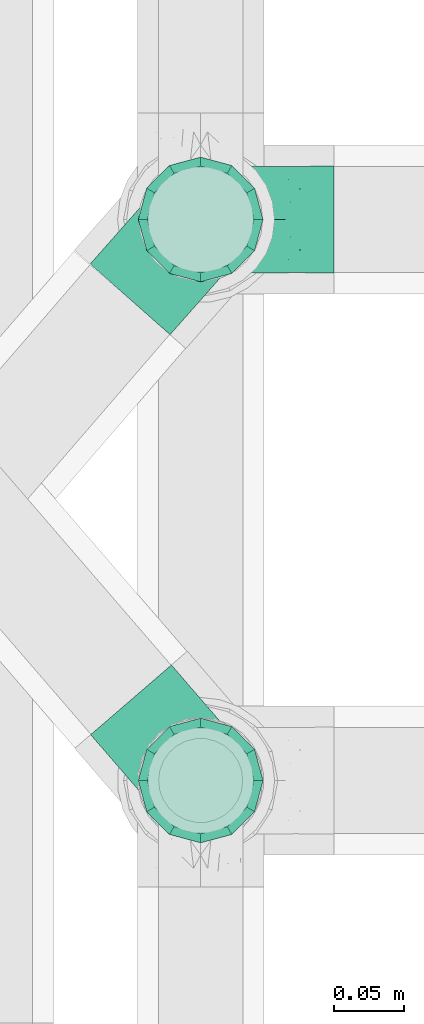
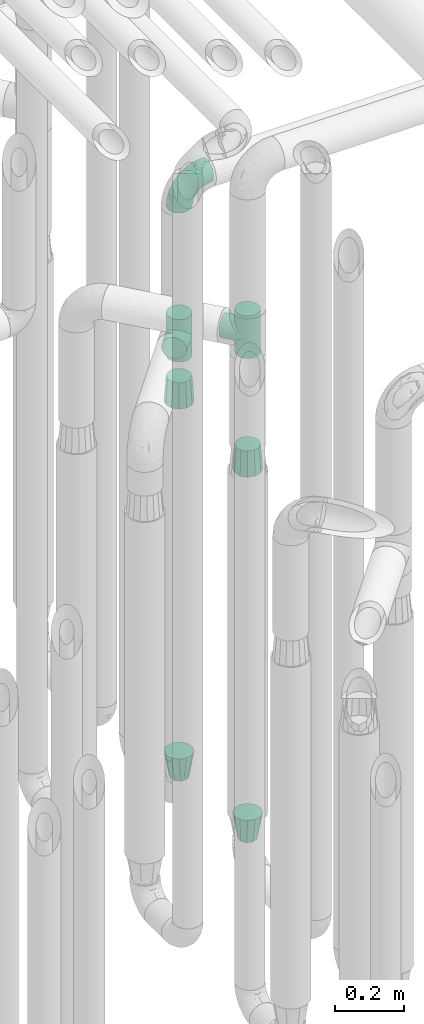
# One storey, part 618 of 827: 7 flow fittings.
"""IFC2X3 building model written with IfcOpenShell, lengths in millimetres."""

from ifc_helpers import new_model, entity, si_unit, converted_unit, derived_unit, direction, frame, origin, place, context, subcontext, project, spatial, faceted_brep, source, transform, mapped, material, type_object, type_shapes, element, save


model = new_model("IFC2X3")

# Units and contexts
model_context = context("Model", 3, precision=0.01, world=origin(), true_north=direction((6.12303176911189e-17, 1.0)))
body_context = subcontext(model_context, "Body", "Model", "MODEL_VIEW")
ifc_project = project(units=[si_unit("LENGTHUNIT", "METRE", prefix="MILLI"), si_unit("AREAUNIT", "SQUARE_METRE"), si_unit("VOLUMEUNIT", "CUBIC_METRE"), converted_unit("PLANEANGLEUNIT", "DEGREE", entity("IfcRatioMeasure", 0.0174532925199433), si_unit("PLANEANGLEUNIT", "RADIAN"), dimensions=[0, 0, 0, 0, 0, 0, 0]), si_unit("MASSUNIT", "GRAM", prefix="KILO"), derived_unit("MASSDENSITYUNIT", [(si_unit("MASSUNIT", "GRAM", prefix="KILO"), 1), (si_unit("LENGTHUNIT", "METRE"), -3)]), derived_unit("MOMENTOFINERTIAUNIT", [(si_unit("LENGTHUNIT", "METRE"), 4)]), si_unit("TIMEUNIT", "SECOND"), si_unit("FREQUENCYUNIT", "HERTZ"), si_unit("THERMODYNAMICTEMPERATUREUNIT", "DEGREE_CELSIUS"), derived_unit("THERMALTRANSMITTANCEUNIT", [(si_unit("MASSUNIT", "GRAM", prefix="KILO"), 1), (si_unit("THERMODYNAMICTEMPERATUREUNIT", "KELVIN"), -1), (si_unit("TIMEUNIT", "SECOND"), -3)]), derived_unit("VOLUMETRICFLOWRATEUNIT", [(si_unit("LENGTHUNIT", "METRE"), 3), (si_unit("TIMEUNIT", "SECOND"), -1)]), derived_unit("MASSFLOWRATEUNIT", [(si_unit("MASSUNIT", "GRAM", prefix="KILO"), 1), (si_unit("TIMEUNIT", "SECOND"), -1)]), derived_unit("ROTATIONALFREQUENCYUNIT", [(si_unit("TIMEUNIT", "SECOND"), -1)]), si_unit("ELECTRICCURRENTUNIT", "AMPERE"), si_unit("ELECTRICVOLTAGEUNIT", "VOLT"), si_unit("POWERUNIT", "WATT"), si_unit("FORCEUNIT", "NEWTON", prefix="KILO"), si_unit("ILLUMINANCEUNIT", "LUX"), si_unit("LUMINOUSFLUXUNIT", "LUMEN"), si_unit("LUMINOUSINTENSITYUNIT", "CANDELA"), derived_unit("USERDEFINED", [(si_unit("MASSUNIT", "GRAM", prefix="KILO"), -1), (si_unit("LENGTHUNIT", "METRE"), -2), (si_unit("TIMEUNIT", "SECOND"), 3), (si_unit("LUMINOUSFLUXUNIT", "LUMEN"), 1)]), derived_unit("LINEARVELOCITYUNIT", [(si_unit("LENGTHUNIT", "METRE"), 1), (si_unit("TIMEUNIT", "SECOND"), -1)]), si_unit("PRESSUREUNIT", "PASCAL"), derived_unit("USERDEFINED", [(si_unit("LENGTHUNIT", "METRE"), -2), (si_unit("MASSUNIT", "GRAM", prefix="KILO"), 1), (si_unit("TIMEUNIT", "SECOND"), -2)]), derived_unit("LINEARFORCEUNIT", [(si_unit("MASSUNIT", "GRAM", prefix="KILO"), 1), (si_unit("LENGTHUNIT", "METRE"), 1), (si_unit("TIMEUNIT", "SECOND"), -2), (si_unit("LENGTHUNIT", "METRE"), -1)]), derived_unit("PLANARFORCEUNIT", [(si_unit("MASSUNIT", "GRAM", prefix="KILO"), 1), (si_unit("LENGTHUNIT", "METRE"), 1), (si_unit("TIMEUNIT", "SECOND"), -2), (si_unit("LENGTHUNIT", "METRE"), -2)])], contexts=[model_context])

# Site, building, storey
site_placement = place(None, origin())
site = spatial("IfcSite", under=ifc_project, at=site_placement, CompositionType="ELEMENT")
building_placement = place(site_placement, origin())
building = spatial("IfcBuilding", under=site, at=building_placement, CompositionType="ELEMENT")
storey_placement = place(building_placement, frame((0.0, 0.0, 28200.0)))
storey = spatial("IfcBuildingStorey", under=building, at=storey_placement, Name="08", CompositionType="ELEMENT", Elevation=28200.0)

# Flow fittings
ifc_material = material()
pipe_fitting_type_1 = type_object("IfcPipeFittingType", Name="ADSK_1", PredefinedType="NOTDEFINED", material=ifc_material)
shared_shape_1 = source(origin(), body_context, "Body", "Brep", [
    faceted_brep([(-95.0, 19.02, -32.95), (-95.0, 9.85, -36.75), (-95.0, 0.0, -38.05), (-95.0, -9.85, -36.75), (-95.0, -19.03, -32.95), (-95.0, -26.91, -26.91), (-95.0, -32.95, -19.03), (-95.0, -36.75, -9.85), (-95.0, -38.05, 0.0), (-95.0, -36.75, 9.85), (-95.0, -32.95, 19.02), (-95.0, -26.91, 26.91), (-95.0, -19.03, 32.95), (-95.0, -9.85, 36.75), (-95.0, 0.0, 38.05), (-95.0, 9.85, 36.75), (-95.0, 19.02, 32.95), (-95.0, 26.91, 26.91), (-95.0, 32.95, 19.02), (-95.0, 36.75, 9.85), (-95.0, 38.05, 0.0), (-95.0, 36.75, -9.85), (-95.0, 32.95, -19.03), (-95.0, 26.91, -26.91), (0.0, 95.0, -38.05), (-9.85, 95.0, -36.75), (-19.02, 95.0, -32.95), (-26.91, 95.0, -26.91), (-32.95, 95.0, -19.03), (-36.75, 95.0, -9.85), (-38.05, 95.0, 0.0), (-36.75, 95.0, 9.85), (-32.95, 95.0, 19.02), (-26.91, 95.0, 26.91), (-19.02, 95.0, 32.95), (-9.85, 95.0, 36.75), (0.0, 95.0, 38.05), (9.85, 95.0, 36.75), (19.03, 95.0, 32.95), (26.91, 95.0, 26.91), (32.95, 95.0, 19.02), (36.75, 95.0, 9.85), (38.05, 95.0, 0.0), (36.75, 95.0, -9.85), (32.95, 95.0, -19.03), (26.91, 95.0, -26.91), (19.03, 95.0, -32.95), (9.85, 95.0, -36.75), (-7.99, -4.96, 6.3), (-0.92, 0.92, 0.0), (4.62, 8.1, 8.01), (-76.19, -35.57, 0.0), (-64.32, -32.32, 12.43), (20.51, 62.45, 28.68), (-60.56, -33.52, 0.0), (-70.4, -13.47, 34.42), (-39.61, -5.88, 32.32), (-49.6, 2.07, 37.1), (-70.34, -28.81, 21.71), (14.64, 40.81, 26.5), (5.88, 39.61, 32.32), (3.59, 20.77, 25.31), (-40.45, 68.06, 16.75), (-62.45, -20.51, 28.68), (-44.52, -26.87, 0.0), (-28.47, -20.22, 0.0), (-26.43, -17.83, 8.75), (-76.1, 39.63, 10.76), (-72.74, 37.58, 18.19), (-60.35, 46.18, 14.61), (-13.4, 13.4, 32.12), (-20.77, -3.59, 25.31), (-14.66, 81.47, 35.56), (-6.22, 71.26, 37.92), (-57.5, 42.48, 22.79), (-15.0, 34.74, 37.7), (-27.1, 12.08, 36.05), (-9.2, 28.81, 35.63), (-79.98, 23.7, 30.95), (-73.68, -4.3, 37.48), (-30.74, 21.67, 37.97), (-62.36, 47.59, 6.79), (-72.71, 32.83, 24.69), (-67.42, 7.02, 37.95), (-32.13, 75.27, 24.51), (-43.46, 51.47, 26.26), (-24.98, 73.15, 31.29), (20.59, 41.28, 19.85), (7.79, 16.09, 15.86), (-73.21, 42.39, 0.0), (-54.73, 54.73, 0.0), (-73.44, 15.79, 35.79), (-5.94, 4.32, 20.43), (28.81, 70.34, 21.71), (32.32, 64.32, 12.43), (-53.59, 26.2, 35.09), (-52.02, 19.31, 37.21), (21.38, 33.53, 10.34), (26.87, 44.52, 0.0), (-48.28, 12.14, 38.05), (4.3, 73.68, 37.48), (-44.08, -25.52, 12.79), (-41.28, -20.59, 19.85), (35.57, 76.19, 0.0), (-47.26, 54.3, 20.18), (-47.4, 61.99, 8.58), (-42.39, 73.21, 0.0), (-39.67, 78.86, 7.21), (-45.69, 36.84, 33.11), (-32.83, 50.13, 33.35), (13.47, 70.4, 34.42), (-18.25, 63.73, 36.07), (-40.63, -13.75, 27.22), (-16.63, 46.37, 37.95), (-53.47, 38.79, 28.59), (-26.07, 48.54, 36.15), (-34.51, 34.51, 36.86), (-2.07, 49.6, 37.1), (-22.79, -10.49, 19.23), (-61.73, 28.67, 31.87), (9.65, 14.7, 0.0), (20.22, 28.47, 0.0), (33.52, 60.56, 0.0), (-11.42, -5.44, 13.25), (-14.7, -9.65, 0.0), (-81.47, 14.66, -35.56), (-62.45, -20.51, -28.68), (-71.26, 6.22, -37.92), (-75.27, 32.13, -24.51), (-73.15, 24.98, -31.29), (13.47, 70.4, -34.42), (5.88, 39.61, -32.32), (-2.07, 49.6, -37.1), (-78.86, 39.67, -7.21), (-70.4, -13.47, -34.42), (-39.61, -5.88, -32.32), (-61.99, 47.4, -8.58), (32.32, 64.32, -12.43), (28.81, 70.34, -21.71), (-63.73, 18.25, -36.07), (-50.13, 32.83, -33.35), (4.3, 73.68, -37.48), (-7.02, 67.42, -37.95), (-39.63, 76.1, -10.76), (-46.18, 60.35, -14.61), (-47.59, 62.36, -6.79), (-64.32, -32.32, -12.43), (-26.2, 53.59, -35.09), (-15.79, 73.44, -35.79), (-19.31, 52.02, -37.21), (-37.58, 72.74, -18.19), (-70.34, -28.81, -21.71), (-42.48, 57.5, -22.79), (-38.79, 53.47, -28.59), (-51.47, 43.46, -26.26), (-32.83, 72.71, -24.69), (-46.37, 16.63, -37.95), (-73.68, -4.3, -37.48), (-41.28, -20.59, -19.85), (-44.08, -25.52, -12.79), (13.75, 40.63, -27.22), (20.51, 62.45, -28.68), (-68.06, 40.45, -16.75), (-54.3, 47.26, -20.18), (-12.14, 48.28, -38.05), (-21.67, 30.74, -37.97), (-36.84, 45.69, -33.11), (-11.42, -5.44, -13.25), (7.79, 16.09, -15.86), (4.62, 8.1, -8.01), (-23.7, 79.98, -30.95), (-26.43, -17.83, -8.75), (-7.99, -4.96, -6.3), (-40.81, -14.64, -26.5), (-20.77, -3.59, -25.31), (-34.74, 15.0, -37.7), (-12.08, 27.1, -36.05), (-28.81, 9.2, -35.63), (-22.79, -10.49, -19.23), (21.38, 33.53, -10.34), (20.59, 41.28, -19.85), (-48.54, 26.07, -36.15), (-49.6, 2.07, -37.1), (-13.4, 13.4, -32.12), (3.59, 20.77, -25.31), (-28.67, 61.73, -31.87), (-34.51, 34.51, -36.86), (-5.94, 4.32, -20.43)], [[[0, 1, 2, 3, 4, 5, 6, 7, 8, 9, 10, 11, 12, 13, 14, 15, 16, 17, 18, 19, 20, 21, 22, 23]], [[24, 25, 26, 27, 28, 29, 30, 31, 32, 33, 34, 35, 36, 37, 38, 39, 40, 41, 42, 43, 44, 45, 46, 47]], [[48, 49, 50]], [[51, 52, 9]], [[53, 39, 38]], [[9, 52, 10]], [[54, 52, 51]], [[55, 56, 57]], [[11, 10, 58]], [[59, 60, 61]], [[32, 31, 62]], [[63, 12, 11]], [[63, 55, 12]], [[64, 65, 66]], [[67, 68, 69]], [[70, 56, 71]], [[35, 72, 73]], [[69, 68, 74]], [[75, 76, 77]], [[16, 78, 17]], [[13, 79, 14]], [[76, 75, 80]], [[67, 69, 81]], [[18, 17, 82]], [[14, 79, 83]], [[20, 19, 67]], [[84, 85, 86]], [[87, 61, 88]], [[89, 81, 90]], [[18, 82, 68]], [[15, 91, 16]], [[14, 83, 15]], [[71, 92, 61]], [[17, 78, 82]], [[93, 87, 94]], [[95, 91, 96]], [[97, 98, 94]], [[86, 72, 34]], [[96, 99, 80]], [[37, 36, 100]], [[40, 39, 93]], [[40, 94, 41]], [[64, 66, 101]], [[93, 94, 40]], [[58, 102, 63]], [[94, 103, 41]], [[94, 87, 97]], [[104, 69, 74]], [[34, 33, 86]], [[105, 69, 104]], [[52, 58, 10]], [[106, 107, 30]], [[108, 109, 85]], [[105, 106, 90]], [[53, 110, 60]], [[86, 111, 72]], [[86, 109, 111]], [[33, 84, 86]], [[12, 55, 13]], [[112, 56, 63]], [[110, 38, 37]], [[34, 72, 35]], [[36, 35, 73]], [[111, 113, 73]], [[105, 107, 106]], [[110, 53, 38]], [[74, 114, 85]], [[91, 15, 83]], [[105, 90, 81]], [[107, 62, 31]], [[33, 32, 84]], [[115, 109, 116]], [[111, 115, 113]], [[100, 73, 117]], [[56, 55, 63]], [[79, 55, 57]], [[102, 118, 112]], [[56, 70, 76]], [[100, 110, 37]], [[117, 77, 60]], [[117, 60, 110]], [[60, 70, 61]], [[58, 52, 101]], [[63, 11, 58]], [[39, 53, 93]], [[87, 93, 53]], [[96, 91, 83]], [[78, 91, 119]], [[32, 62, 84]], [[84, 62, 104]], [[86, 85, 109]], [[85, 114, 108]], [[80, 113, 116]], [[117, 73, 113]], [[80, 116, 96]], [[80, 57, 76]], [[71, 112, 118]], [[61, 87, 59]], [[62, 107, 105]], [[97, 120, 121]], [[70, 71, 61]], [[71, 118, 92]], [[73, 100, 36]], [[110, 100, 117]], [[55, 79, 13]], [[83, 79, 57]], [[96, 83, 99]], [[116, 108, 95]], [[50, 97, 88]], [[97, 87, 88]], [[50, 49, 120]], [[122, 94, 98]], [[89, 20, 67]], [[105, 81, 69]], [[89, 67, 81]], [[68, 19, 18]], [[68, 67, 19]], [[74, 68, 82]], [[114, 82, 119]], [[74, 85, 104]], [[82, 114, 74]], [[114, 119, 108]], [[95, 108, 119]], [[116, 109, 108]], [[123, 48, 50]], [[97, 50, 120]], [[123, 50, 88]], [[91, 95, 119]], [[116, 95, 96]], [[84, 104, 85]], [[104, 62, 105]], [[83, 57, 99]], [[57, 80, 99]], [[66, 48, 123]], [[66, 124, 48]], [[118, 66, 123]], [[124, 66, 65]], [[66, 118, 101]], [[54, 64, 52]], [[124, 49, 48]], [[30, 107, 31]], [[91, 78, 16]], [[82, 78, 119]], [[56, 76, 57]], [[77, 76, 70]], [[60, 77, 70]], [[77, 117, 75]], [[117, 113, 75]], [[113, 80, 75]], [[9, 8, 51]], [[103, 94, 122]], [[103, 42, 41]], [[73, 72, 111]], [[113, 115, 116]], [[111, 109, 115]], [[102, 112, 63]], [[71, 56, 112]], [[118, 102, 101]], [[92, 123, 88]], [[123, 92, 118]], [[61, 92, 88]], [[87, 53, 59]], [[60, 59, 53]], [[97, 121, 98]], [[58, 101, 102]], [[64, 101, 52]], [[125, 1, 0]], [[126, 5, 4]], [[2, 1, 127]], [[1, 125, 127]], [[128, 129, 23]], [[130, 131, 132]], [[89, 133, 20]], [[126, 134, 135]], [[136, 89, 90]], [[137, 138, 44]], [[139, 129, 140]], [[24, 141, 142]], [[143, 144, 145]], [[125, 129, 139]], [[6, 146, 7]], [[147, 148, 149]], [[146, 51, 7]], [[143, 150, 144]], [[146, 6, 151]], [[152, 153, 154]], [[126, 4, 134]], [[0, 23, 129]], [[28, 155, 150]], [[43, 42, 103]], [[54, 146, 64]], [[139, 156, 127]], [[157, 3, 2]], [[151, 158, 159]], [[160, 131, 161]], [[22, 21, 162]], [[136, 144, 163]], [[149, 164, 165]], [[24, 142, 25]], [[166, 140, 154]], [[154, 129, 128]], [[143, 30, 29]], [[167, 168, 169]], [[155, 28, 27]], [[26, 170, 27]], [[171, 167, 172]], [[26, 25, 148]], [[27, 170, 155]], [[173, 135, 174]], [[144, 150, 152]], [[175, 176, 177]], [[24, 47, 141]], [[45, 161, 46]], [[148, 25, 142]], [[176, 175, 165]], [[64, 159, 171]], [[138, 45, 44]], [[130, 46, 161]], [[137, 44, 43]], [[178, 159, 158]], [[137, 103, 122]], [[163, 144, 152]], [[136, 133, 89]], [[103, 137, 43]], [[6, 5, 151]], [[178, 158, 173]], [[134, 4, 3]], [[178, 173, 174]], [[137, 98, 179]], [[145, 90, 106]], [[138, 180, 161]], [[46, 130, 47]], [[136, 90, 145]], [[133, 162, 21]], [[23, 22, 128]], [[139, 140, 181]], [[139, 181, 156]], [[157, 127, 182]], [[157, 134, 3]], [[182, 177, 135]], [[182, 135, 134]], [[135, 183, 174]], [[131, 130, 161]], [[141, 130, 132]], [[160, 180, 184]], [[131, 183, 176]], [[5, 126, 151]], [[158, 151, 126]], [[180, 138, 137]], [[161, 45, 138]], [[149, 148, 142]], [[170, 148, 185]], [[22, 162, 128]], [[128, 162, 163]], [[129, 154, 140]], [[154, 153, 166]], [[165, 156, 186]], [[182, 127, 156]], [[165, 186, 149]], [[165, 132, 176]], [[131, 184, 183]], [[187, 167, 178]], [[184, 168, 187]], [[167, 169, 172]], [[184, 180, 168]], [[174, 183, 184]], [[127, 157, 2]], [[134, 157, 182]], [[130, 141, 47]], [[142, 141, 132]], [[149, 142, 164]], [[186, 166, 147]], [[180, 179, 168]], [[169, 179, 120]], [[137, 179, 180]], [[179, 121, 120]], [[106, 30, 143]], [[136, 145, 144]], [[106, 143, 145]], [[150, 29, 28]], [[150, 143, 29]], [[152, 150, 155]], [[153, 155, 185]], [[152, 154, 163]], [[155, 153, 152]], [[153, 185, 166]], [[147, 166, 185]], [[186, 140, 166]], [[169, 120, 49]], [[169, 49, 172]], [[179, 169, 168]], [[148, 147, 185]], [[186, 147, 149]], [[128, 163, 154]], [[163, 162, 136]], [[142, 132, 164]], [[132, 165, 164]], [[171, 124, 65]], [[124, 171, 172]], [[64, 146, 159]], [[171, 159, 178]], [[171, 65, 64]], [[172, 49, 124]], [[162, 133, 136]], [[20, 133, 21]], [[148, 170, 26]], [[155, 170, 185]], [[131, 176, 132]], [[177, 176, 183]], [[135, 177, 183]], [[177, 182, 175]], [[182, 156, 175]], [[156, 165, 175]], [[51, 146, 54]], [[51, 8, 7]], [[129, 125, 0]], [[127, 125, 139]], [[140, 186, 181]], [[156, 181, 186]], [[158, 126, 173]], [[135, 173, 126]], [[187, 178, 174]], [[171, 178, 167]], [[184, 187, 174]], [[167, 187, 168]], [[180, 160, 161]], [[184, 131, 160]], [[98, 137, 122]], [[98, 121, 179]], [[151, 159, 146]]]),
])
type_shapes(pipe_fitting_type_1, [shared_shape_1])
flow_fitting_1_placement = place(storey_placement, frame((36975.03, 11730.2, 2600.0), z_axis=(0.0, 1.0, 0.0), x_axis=(0.0, 0.0, 1.0)))
element("IfcFlowFitting", 1, at=flow_fitting_1_placement, inside=storey, type_object=pipe_fitting_type_1, material=ifc_material, Name="ADSK_1", ObjectType="ADSK_1", context=body_context, shape_type="MappedRepresentation", body=[
    mapped(shared_shape_1, transform((0.0, 0.0, 0.0), scale=1.0)),
])
pipe_fitting_type_2 = type_object("IfcPipeFittingType", Name="ADSK_1", PredefinedType="NOTDEFINED", material=ifc_material)
shared_shape_2 = source(origin(), body_context, "Body", "Brep", [
    faceted_brep([(-76.0, 9.85, -36.75), (-76.0, 0.0, -38.05), (-76.0, -9.85, -36.75), (-76.0, -19.03, -32.95), (-76.0, -22.97, -29.93), (-76.0, -26.91, -26.91), (-76.0, -29.93, -22.97), (-76.0, -32.95, -19.03), (-76.0, -34.85, -14.44), (-76.0, -36.75, -9.85), (-76.0, -38.05, 0.0), (-76.0, -36.75, 9.85), (-76.0, -34.85, 14.44), (-76.0, -32.95, 19.02), (-76.0, -29.93, 22.97), (-76.0, -26.91, 26.91), (-76.0, -22.97, 29.93), (-76.0, -19.03, 32.95), (-76.0, -9.85, 36.75), (-76.0, 0.0, 38.05), (-76.0, 9.85, 36.75), (-76.0, 19.02, 32.95), (-76.0, 26.91, 26.91), (-76.0, 32.95, 19.02), (-76.0, 36.75, 9.85), (-76.0, 38.05, 0.0), (-76.0, 36.75, -9.85), (-76.0, 32.95, -19.03), (-76.0, 26.91, -26.91), (-76.0, 19.02, -32.95), (76.0, 26.91, -26.91), (76.0, 32.95, -19.03), (76.0, 36.75, -9.85), (76.0, 38.05, 0.0), (76.0, 36.75, 9.85), (76.0, 32.95, 19.02), (76.0, 26.91, 26.91), (76.0, 19.02, 32.95), (76.0, 9.85, 36.75), (76.0, 0.0, 38.05), (76.0, -9.85, 36.75), (76.0, -19.03, 32.95), (76.0, -22.97, 29.93), (76.0, -26.91, 26.91), (76.0, -29.93, 22.97), (76.0, -32.95, 19.02), (76.0, -34.85, 14.44), (76.0, -36.75, 9.85), (76.0, -38.05, 0.0), (76.0, -36.75, -9.85), (76.0, -34.85, -14.44), (76.0, -32.95, -19.03), (76.0, -29.93, -22.97), (76.0, -26.91, -26.91), (76.0, -22.97, -29.93), (76.0, -19.03, -32.95), (76.0, -9.85, -36.75), (76.0, 0.0, -38.05), (76.0, 9.85, -36.75), (76.0, 19.02, -32.95), (36.99, -36.99, 8.94), (38.05, -38.05, 0.0), (-36.99, -36.99, 8.94), (-38.05, -38.05, 0.0), (35.51, -35.51, 12.97), (34.04, -34.04, 17.0), (18.81, -18.81, 33.08), (29.74, -29.74, 23.73), (24.56, -24.56, 29.06), (-35.51, -35.51, 12.97), (-34.04, -34.04, 17.0), (-18.81, -18.81, 33.08), (-29.74, -29.74, 23.73), (-24.56, -24.56, 29.06), (-12.7, -12.7, 35.87), (6.4, -6.4, 37.51), (12.7, -12.7, 35.87), (0.0, 0.0, 38.05), (-6.4, -6.4, 37.51), (6.4, -6.4, -37.51), (0.0, 0.0, -38.05), (12.7, -12.7, -35.87), (-24.56, -24.56, -29.06), (-6.4, -6.4, -37.51), (-35.51, -35.51, -12.97), (-36.99, -36.99, -8.94), (-29.74, -29.74, -23.73), (-12.7, -12.7, -35.87), (18.81, -18.81, -33.08), (24.56, -24.56, -29.06), (-34.04, -34.04, -17.0), (29.74, -29.74, -23.73), (36.99, -36.99, -8.94), (35.51, -35.51, -12.97), (34.04, -34.04, -17.0), (-18.81, -18.81, -33.08), (9.85, -76.0, -36.75), (19.03, -76.0, -32.95), (26.91, -76.0, -26.91), (32.95, -76.0, -19.03), (36.75, -76.0, -9.85), (38.05, -76.0, 0.0), (36.75, -76.0, 9.85), (32.95, -76.0, 19.02), (26.91, -76.0, 26.91), (19.03, -76.0, 32.95), (9.85, -76.0, 36.75), (0.0, -76.0, 38.05), (-9.85, -76.0, 36.75), (-19.02, -76.0, 32.95), (-26.91, -76.0, 26.91), (-32.95, -76.0, 19.02), (-36.75, -76.0, 9.85), (-38.05, -76.0, 0.0), (-36.75, -76.0, -9.85), (-32.95, -76.0, -19.03), (-26.91, -76.0, -26.91), (-19.02, -76.0, -32.95), (-9.85, -76.0, -36.75), (0.0, -76.0, -38.05)], [[[0, 1, 2, 3, 4, 5, 6, 7, 8, 9, 10, 11, 12, 13, 14, 15, 16, 17, 18, 19, 20, 21, 22, 23, 24, 25, 26, 27, 28, 29]], [[30, 31, 32, 33, 34, 35, 36, 37, 38, 39, 40, 41, 42, 43, 44, 45, 46, 47, 48, 49, 50, 51, 52, 53, 54, 55, 56, 57, 58, 59]], [[48, 47, 60]], [[60, 61, 48]], [[62, 10, 63]], [[47, 46, 64]], [[46, 45, 65]], [[41, 66, 42]], [[43, 67, 45, 44]], [[67, 43, 68]], [[45, 67, 65]], [[68, 43, 42]], [[11, 69, 12]], [[70, 12, 69]], [[10, 62, 11]], [[11, 62, 69]], [[71, 17, 16]], [[72, 73, 15]], [[72, 15, 14, 13]], [[15, 73, 16]], [[71, 74, 17]], [[72, 13, 70]], [[46, 65, 64]], [[42, 66, 68]], [[40, 39, 75]], [[47, 64, 60]], [[66, 41, 76]], [[75, 76, 40]], [[75, 39, 77]], [[78, 77, 19]], [[76, 41, 40]], [[23, 22, 36, 35]], [[24, 23, 35, 34]], [[21, 20, 38, 37]], [[22, 21, 37, 36]], [[38, 20, 19, 77, 39]], [[25, 24, 34, 33]], [[70, 13, 12]], [[78, 18, 74]], [[18, 78, 19]], [[18, 17, 74]], [[71, 16, 73]], [[28, 27, 31, 30]], [[26, 32, 31, 27]], [[25, 33, 32, 26]], [[29, 28, 30, 59]], [[57, 56, 79]], [[58, 57, 80, 1, 0]], [[79, 56, 81]], [[82, 5, 4]], [[59, 58, 0, 29]], [[56, 55, 81]], [[57, 79, 80]], [[80, 83, 1]], [[9, 84, 85]], [[86, 7, 6, 5]], [[83, 87, 2]], [[1, 83, 2]], [[87, 3, 2]], [[88, 54, 89]], [[54, 53, 89]], [[8, 90, 84]], [[88, 55, 54]], [[91, 89, 53]], [[52, 51, 91, 53]], [[55, 88, 81]], [[49, 92, 93]], [[92, 49, 48]], [[94, 50, 93]], [[61, 92, 48]], [[85, 63, 10]], [[51, 94, 91]], [[82, 4, 95]], [[49, 93, 50]], [[4, 3, 95]], [[5, 82, 86]], [[94, 51, 50]], [[95, 3, 87]], [[9, 8, 84]], [[90, 8, 7]], [[9, 85, 10]], [[90, 7, 86]], [[96, 97, 98, 99, 100, 101, 102, 103, 104, 105, 106, 107, 108, 109, 110, 111, 112, 113, 114, 115, 116, 117, 118, 119]], [[62, 63, 113]], [[112, 62, 113]], [[110, 109, 73]], [[72, 111, 110]], [[70, 112, 111]], [[74, 109, 108]], [[112, 70, 69, 62]], [[73, 72, 110]], [[70, 111, 72]], [[74, 71, 109]], [[107, 77, 78]], [[74, 108, 78]], [[73, 109, 71]], [[78, 108, 107]], [[75, 107, 106]], [[105, 76, 106]], [[103, 102, 65]], [[67, 104, 103]], [[68, 105, 104]], [[60, 102, 101]], [[68, 66, 105]], [[76, 75, 106]], [[66, 76, 105]], [[61, 60, 101]], [[65, 67, 103]], [[102, 60, 64, 65]], [[68, 104, 67]], [[107, 75, 77]], [[61, 101, 92]], [[100, 92, 101]], [[98, 97, 89]], [[94, 100, 99]], [[98, 91, 99]], [[81, 97, 96]], [[100, 94, 93, 92]], [[89, 91, 98]], [[94, 99, 91]], [[81, 88, 97]], [[119, 80, 79]], [[81, 96, 79]], [[89, 97, 88]], [[79, 96, 119]], [[83, 119, 118]], [[117, 87, 118]], [[115, 114, 90]], [[86, 116, 115]], [[82, 117, 116]], [[85, 114, 113]], [[82, 95, 117]], [[87, 83, 118]], [[95, 87, 117]], [[63, 85, 113]], [[90, 86, 115]], [[114, 85, 84, 90]], [[82, 116, 86]], [[119, 83, 80]]]),
])
type_shapes(pipe_fitting_type_2, [shared_shape_2])
for number, where, z_axis, x_axis, name in (
    (2, (36975.03, 11330.2, 2305.0), (0.757098240256198, 0.653301044389926, 0.0), (0.0, 0.0, 1.0), "ADSK_1"),
    (3, (36975.03, 11730.2, 2050.0), (-0.749374472575658, 0.662146433843719, 0.0), (0.0, 0.0, 1.0), "ADSK_1"),
):
    element("IfcFlowFitting", number, at=place(storey_placement, frame(where, z_axis=z_axis, x_axis=x_axis)), inside=storey, type_object=pipe_fitting_type_2, material=ifc_material, Name=name, ObjectType="ADSK_1", context=body_context, shape_type="MappedRepresentation", body=[
        mapped(shared_shape_2, transform((0.0, 0.0, 0.0), scale=1.0)),
    ])
pipe_fitting_type_3 = type_object("IfcPipeFittingType", Name="ADSK_1", PredefinedType="NOTDEFINED", material=ifc_material)
shared_shape_3 = source(origin(), body_context, "Body", "Brep", [
    faceted_brep([(89.0, -44.45, 0.0), (89.0, -42.1, -8.76), (89.0, -38.49, -22.22), (89.0, -30.36, -30.36), (89.0, -22.23, -38.49), (89.0, -11.11, -41.47), (89.0, 0.0, -44.45), (89.0, 11.11, -41.47), (89.0, 22.22, -38.49), (89.0, 30.36, -30.36), (89.0, 38.49, -22.22), (89.0, 42.1, -8.76), (89.0, 44.45, 0.0), (89.0, 42.1, 8.76), (89.0, 38.49, 22.23), (89.0, 30.36, 30.36), (89.0, 22.22, 38.49), (89.0, 11.11, 41.47), (89.0, 0.0, 44.45), (89.0, -11.11, 41.47), (89.0, -22.23, 38.49), (89.0, -30.36, 30.36), (89.0, -38.49, 22.23), (89.0, -42.1, 8.76), (0.0, 30.15, 0.0), (0.0, 27.27, -8.86), (0.0, 24.39, -17.72), (0.0, 16.85, -23.2), (0.0, 9.32, -28.67), (0.0, 0.0, -28.67), (0.0, -9.32, -28.67), (0.0, -16.85, -23.2), (0.0, -24.39, -17.72), (0.0, -27.27, -8.86), (0.0, -30.15, 0.0), (0.0, -27.27, 8.86), (0.0, -24.39, 17.72), (0.0, -16.85, 23.2), (0.0, -9.32, 28.67), (0.0, 0.0, 28.67), (0.0, 9.32, 28.67), (0.0, 16.85, 23.2), (0.0, 24.39, 17.72), (0.0, 27.27, 8.86)], [[[0, 1, 2, 3, 4, 5, 6, 7, 8, 9, 10, 11, 12, 13, 14, 15, 16, 17, 18, 19, 20, 21, 22, 23]], [[24, 25, 26, 27, 28, 29, 30, 31, 32, 33, 34, 35, 36, 37, 38, 39, 40, 41, 42, 43]], [[2, 33, 32]], [[28, 7, 29]], [[29, 5, 30]], [[24, 12, 11]], [[3, 32, 31]], [[34, 1, 0]], [[1, 34, 33]], [[8, 28, 27]], [[2, 1, 33]], [[31, 4, 3]], [[2, 32, 3]], [[11, 25, 24]], [[26, 10, 9]], [[10, 25, 11]], [[28, 8, 7]], [[27, 26, 9]], [[26, 25, 10]], [[31, 30, 4]], [[8, 27, 9]], [[29, 7, 6]], [[5, 29, 6]], [[5, 4, 30]], [[14, 43, 42]], [[38, 19, 39]], [[39, 17, 40]], [[34, 0, 23]], [[15, 42, 41]], [[24, 13, 12]], [[13, 24, 43]], [[20, 38, 37]], [[14, 13, 43]], [[41, 16, 15]], [[14, 42, 15]], [[23, 35, 34]], [[36, 22, 21]], [[22, 35, 23]], [[38, 20, 19]], [[37, 36, 21]], [[36, 35, 22]], [[41, 40, 16]], [[20, 37, 21]], [[39, 19, 18]], [[17, 39, 18]], [[17, 16, 40]]]),
])
type_shapes(pipe_fitting_type_3, [shared_shape_3])
flow_fitting_2_placement = place(storey_placement, frame((36975.03, 11330.2, 500.0), z_axis=(1.0, 0.0, 0.0), x_axis=(0.0, 0.0, 1.0)))
element("IfcFlowFitting", 4, at=flow_fitting_2_placement, inside=storey, type_object=pipe_fitting_type_3, material=ifc_material, Name="ADSK_1", ObjectType="ADSK_1", context=body_context, shape_type="MappedRepresentation", body=[
    mapped(shared_shape_3, transform((0.0, 0.0, 0.0), scale=1.0)),
])
pipe_fitting_type_4 = type_object("IfcPipeFittingType", Name="ADSK_1", PredefinedType="NOTDEFINED", material=ifc_material)
shared_shape_4 = source(origin(), body_context, "Body", "Brep", [
    faceted_brep([(89.0, 38.05, 0.0), (89.0, 35.5, 9.51), (89.0, 32.95, 19.03), (89.0, 25.99, 25.99), (89.0, 19.02, 32.95), (89.0, 9.51, 35.5), (89.0, 0.0, 38.05), (89.0, -9.51, 35.5), (89.0, -19.03, 32.95), (89.0, -25.99, 25.99), (89.0, -32.95, 19.03), (89.0, -35.5, 9.51), (89.0, -38.05, 0.0), (89.0, -35.5, -9.51), (89.0, -32.95, -19.02), (89.0, -25.99, -25.99), (89.0, -19.03, -32.95), (89.0, -9.51, -35.5), (89.0, 0.0, -38.05), (89.0, 9.51, -35.5), (89.0, 19.02, -32.95), (89.0, 25.99, -25.99), (89.0, 32.95, -19.03), (89.0, 35.5, -9.51), (0.0, -38.49, 22.22), (0.0, -30.36, 30.36), (0.0, -22.22, 38.49), (0.0, -11.11, 41.47), (0.0, 0.0, 44.45), (0.0, 11.11, 41.47), (0.0, 22.23, 38.49), (0.0, 30.36, 30.36), (0.0, 38.49, 22.22), (0.0, 41.96, 9.31), (0.0, 44.45, 0.0), (0.0, 41.47, -11.11), (0.0, 38.49, -22.23), (0.0, 30.36, -30.36), (0.0, 22.23, -38.49), (0.0, 11.11, -41.47), (0.0, 0.0, -44.45), (0.0, -11.11, -41.47), (0.0, -22.23, -38.49), (0.0, -30.36, -30.36), (0.0, -38.49, -22.23), (0.0, -41.96, -9.31), (0.0, -44.45, 0.0), (0.0, -41.47, 11.11)], [[[0, 1, 2, 3, 4, 5, 6, 7, 8, 9, 10, 11, 12, 13, 14, 15, 16, 17, 18, 19, 20, 21, 22, 23]], [[24, 25, 26, 27, 28, 29, 30, 31, 32, 33, 34, 35, 36, 37, 38, 39, 40, 41, 42, 43, 44, 45, 46, 47]], [[23, 22, 36, 35, 34, 0]], [[39, 38, 20, 19, 18, 40]], [[38, 37, 36, 22, 21, 20]], [[43, 42, 16, 15, 14, 44]], [[41, 40, 18, 17, 16, 42]], [[12, 46, 45, 44, 14, 13]], [[11, 10, 24, 47, 46, 12]], [[27, 26, 8, 7, 6, 28]], [[26, 25, 24, 10, 9, 8]], [[31, 30, 4, 3, 2, 32]], [[29, 28, 6, 5, 4, 30]], [[0, 34, 33, 32, 2, 1]]]),
])
type_shapes(pipe_fitting_type_4, [shared_shape_4])
for number, where, z_axis, x_axis, name in (
    (5, (36975.03, 11330.2, 1811.0), (1.0, 0.0, 0.0), (0.0, 0.0, 1.0), "ADSK_1"),
    (6, (36975.03, 11730.2, 1811.0), (1.0, 0.0, 0.0), (0.0, 0.0, 1.0), "ADSK_1"),
):
    element("IfcFlowFitting", number, at=place(storey_placement, frame(where, z_axis=z_axis, x_axis=x_axis)), inside=storey, type_object=pipe_fitting_type_4, material=ifc_material, Name=name, ObjectType="ADSK_1", context=body_context, shape_type="MappedRepresentation", body=[
        mapped(shared_shape_4, transform((0.0, 0.0, 0.0), scale=1.0)),
    ])
pipe_fitting_type_5 = type_object("IfcPipeFittingType", Name="ADSK_1", PredefinedType="NOTDEFINED", material=ifc_material)
shared_shape_5 = source(origin(), body_context, "Body", "Brep", [
    faceted_brep([(89.0, 38.49, -22.22), (89.0, 42.1, -8.76), (89.0, 44.45, 0.0), (89.0, 42.1, 8.76), (89.0, 38.49, 22.23), (89.0, 30.36, 30.36), (89.0, 22.23, 38.49), (89.0, 11.11, 41.47), (89.0, 0.0, 44.45), (89.0, -11.11, 41.47), (89.0, -22.22, 38.49), (89.0, -30.36, 30.36), (89.0, -38.49, 22.23), (89.0, -42.1, 8.76), (89.0, -44.45, 0.0), (89.0, -42.1, -8.76), (89.0, -38.49, -22.22), (89.0, -30.36, -30.36), (89.0, -22.22, -38.49), (89.0, -11.11, -41.47), (89.0, 0.0, -44.45), (89.0, 11.11, -41.47), (89.0, 22.23, -38.49), (89.0, 30.36, -30.36), (0.0, -24.39, -17.72), (0.0, -27.27, -8.86), (0.0, -30.15, 0.0), (0.0, -27.27, 8.86), (0.0, -24.39, 17.72), (0.0, -16.85, 23.2), (0.0, -9.32, 28.67), (0.0, 0.0, 28.67), (0.0, 9.32, 28.67), (0.0, 16.85, 23.2), (0.0, 24.39, 17.72), (0.0, 27.27, 8.86), (0.0, 30.15, 0.0), (0.0, 27.27, -8.86), (0.0, 24.39, -17.72), (0.0, 16.85, -23.2), (0.0, 9.32, -28.67), (0.0, 0.0, -28.67), (0.0, -9.32, -28.67), (0.0, -16.85, -23.2)], [[[0, 1, 2, 3, 4, 5, 6, 7, 8, 9, 10, 11, 12, 13, 14, 15, 16, 17, 18, 19, 20, 21, 22, 23]], [[24, 25, 26, 27, 28, 29, 30, 31, 32, 33, 34, 35, 36, 37, 38, 39, 40, 41, 42, 43]], [[38, 37, 0]], [[41, 19, 42]], [[40, 21, 41]], [[15, 14, 26]], [[39, 38, 23]], [[2, 1, 36]], [[37, 36, 1]], [[43, 42, 18]], [[37, 1, 0]], [[23, 22, 39]], [[23, 38, 0]], [[26, 25, 15]], [[17, 16, 24]], [[15, 25, 16]], [[19, 18, 42]], [[17, 24, 43]], [[16, 25, 24]], [[22, 40, 39]], [[17, 43, 18]], [[20, 19, 41]], [[20, 41, 21]], [[40, 22, 21]], [[28, 27, 12]], [[31, 7, 32]], [[30, 9, 31]], [[3, 2, 36]], [[29, 28, 11]], [[14, 13, 26]], [[27, 26, 13]], [[33, 32, 6]], [[27, 13, 12]], [[11, 10, 29]], [[11, 28, 12]], [[36, 35, 3]], [[5, 4, 34]], [[3, 35, 4]], [[7, 6, 32]], [[5, 34, 33]], [[4, 35, 34]], [[10, 30, 29]], [[5, 33, 6]], [[8, 7, 31]], [[8, 31, 9]], [[30, 10, 9]]]),
])
type_shapes(pipe_fitting_type_5, [shared_shape_5])
flow_fitting_3_placement = place(storey_placement, frame((36975.03, 11730.2, 476.0), z_axis=(0.0, 1.0, 0.0), x_axis=(0.0, 0.0, 1.0)))
element("IfcFlowFitting", 7, at=flow_fitting_3_placement, inside=storey, type_object=pipe_fitting_type_5, material=ifc_material, Name="ADSK_1", ObjectType="ADSK_1", context=body_context, shape_type="MappedRepresentation", body=[
    mapped(shared_shape_5, transform((0.0, 0.0, 0.0), scale=1.0)),
])

save(model, "model.ifc")
